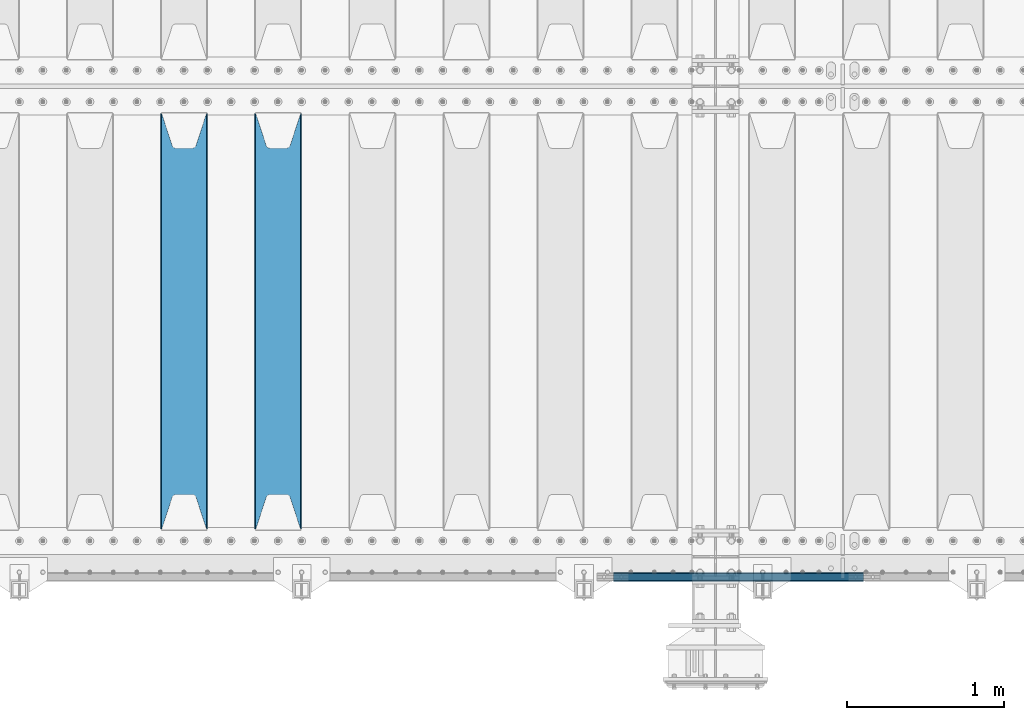
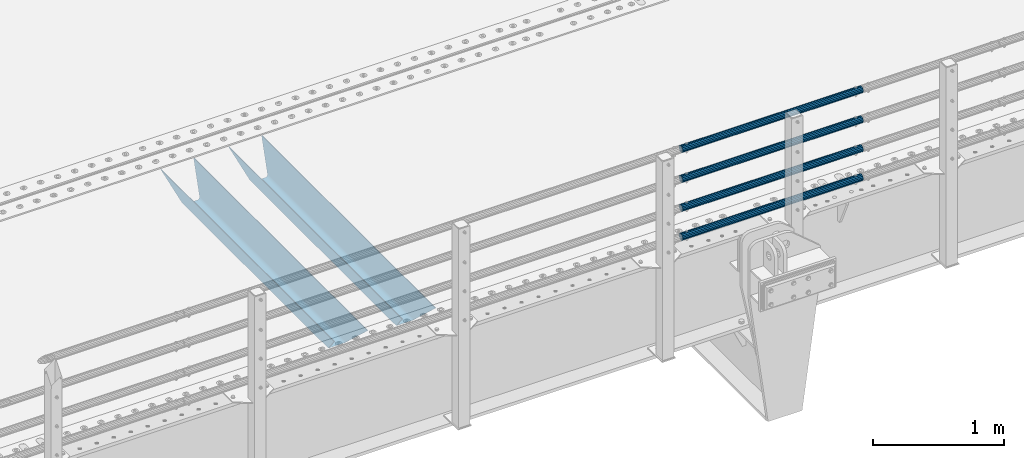
# One storey, part 101 of 219: 6 beams.
"""IFC2X3 building model written with IfcOpenShell, lengths in millimetres."""

import ifcopenshell
import ifcopenshell.guid

model = None  # the IFC model being written
_history = None  # IfcOwnerHistory: only IFC2X3 demands one
_inside = {}  # id of a spatial element -> (the spatial element, [elements in it])
_under = {}  # id of a project, library or spatial element -> (it, [spatial elements below it])
_declared = {}  # id of a project -> (the project, [libraries it declares])
_typed = {}  # id of a type object -> (the type object, [elements of that type])
_made_of = {}  # id of a material, layer set ... -> (it, [elements and type objects made of it])


def new_model(schema):
    """Start an empty IFC model of exactly this schema.

    Asked for "IFC4X3", IfcOpenShell would pick the latest addendum, in which some entities
    have other attributes; the version numbers below select the first issue.
    IFC2X3 requires an IfcOwnerHistory on every rooted entity: one is made here for all.
    """
    global model, _history
    if schema == "IFC4X3":
        model = ifcopenshell.file(schema_version=(4, 3, 0, 0))
    else:
        model = ifcopenshell.file(schema=schema)
    _inside.clear()
    _under.clear()
    _declared.clear()
    _typed.clear()
    _made_of.clear()
    _history = None
    if model.schema == "IFC2X3":
        org = make("IfcOrganization", Name="unknown")
        user = make(
            "IfcPersonAndOrganization",
            ThePerson=make("IfcPerson", FamilyName="unknown"),
            TheOrganization=org,
        )
        app = make(
            "IfcApplication",
            ApplicationDeveloper=org,
            Version="unknown",
            ApplicationFullName="unknown",
            ApplicationIdentifier="unknown",
        )
        _history = make(
            "IfcOwnerHistory",
            OwningUser=user,
            OwningApplication=app,
            ChangeAction="ADDED",
            CreationDate=0,
        )
    return model


def make(cls, **values):
    """One entity of the class cls with the attributes given. An attribute that is None is left unset."""
    return model.create_entity(
        cls, **{name: value for name, value in values.items() if value is not None}
    )


def rooted(cls, **values):
    """An entity with a GlobalId (a new one), such as an element, a storey or a relation."""
    return make(cls, GlobalId=ifcopenshell.guid.new(), OwnerHistory=_history, **values)


def si_unit(unit_type, name, prefix=None):
    """IfcSIUnit, for example si_unit("LENGTHUNIT", "METRE", prefix="MILLI")."""
    return make("IfcSIUnit", UnitType=unit_type, Prefix=prefix, Name=name)


def assignment(units):
    """IfcUnitAssignment: the units of a project."""
    return None if units is None else make("IfcUnitAssignment", Units=units)


def point(xyz):
    """IfcCartesianPoint."""
    return None if xyz is None else make("IfcCartesianPoint", Coordinates=xyz)


def direction(xyz):
    """IfcDirection."""
    return None if xyz is None else make("IfcDirection", DirectionRatios=xyz)


def frame(location, z_axis=None, x_axis=None):
    """IfcAxis2Placement3D, a coordinate frame: its origin and axes. An axis left out is left unset."""
    return make(
        "IfcAxis2Placement3D",
        Location=point(location),
        Axis=direction(z_axis),
        RefDirection=direction(x_axis),
    )


def origin_with_axes():
    """The frame at (0, 0, 0) with the z axis (0, 0, 1) and the x axis (1, 0, 0) written out."""
    return frame((0.0, 0.0, 0.0), z_axis=(0.0, 0.0, 1.0), x_axis=(1.0, 0.0, 0.0))


def place(relative_to, where):
    """IfcLocalPlacement: puts the frame where relative to a parent placement (None: the world)."""
    return make(
        "IfcLocalPlacement", PlacementRelTo=relative_to, RelativePlacement=where
    )


def context(
    kind, dimensions, precision=None, world=None, true_north=None, identifier=None
):
    """IfcGeometricRepresentationContext, for example the 3D "Model" context."""
    return make(
        "IfcGeometricRepresentationContext",
        ContextIdentifier=identifier,
        ContextType=kind,
        CoordinateSpaceDimension=dimensions,
        Precision=precision,
        WorldCoordinateSystem=world,
        TrueNorth=true_north,
    )


def subcontext(parent, identifier, kind, view, scale=None):
    """IfcGeometricRepresentationSubContext, for example "Body" below "Model"."""
    return make(
        "IfcGeometricRepresentationSubContext",
        ContextIdentifier=identifier,
        ContextType=kind,
        ParentContext=parent,
        TargetScale=scale,
        TargetView=view,
    )


def project(units=None, contexts=None):
    """IfcProject with its units and contexts."""
    return rooted(
        "IfcProject",
        Name="project",
        RepresentationContexts=contexts,
        UnitsInContext=assignment(units),
    )


def spatial(cls, under=None, at=None, **own):
    """A site, building, storey or space (cls), placed at a placement, below another one or the project."""
    s = rooted(cls, ObjectPlacement=at, **own)
    if under is not None:
        _under.setdefault(under.id(), (under, []))[1].append(s)
    return s


def faces_of(points, faces, orient=None, outer=None):
    """IfcFace entities. A face is a list of loops; a loop is a list of indices into points, from 0.

    orient and outer hold one flag for each loop. By default every Orientation is true, the
    first loop of a face is its IfcFaceOuterBound and the others are IfcFaceBound.
    """
    made = []
    for i, loops in enumerate(faces):
        bounds = []
        for j, loop in enumerate(loops):
            is_outer = j == 0 if outer is None else outer[i][j]
            bounds.append(
                make(
                    "IfcFaceOuterBound" if is_outer else "IfcFaceBound",
                    Bound=make("IfcPolyLoop", Polygon=[points[k] for k in loop]),
                    Orientation=True if orient is None else orient[i][j],
                )
            )
        made.append(make("IfcFace", Bounds=bounds))
    return made


def faceted_brep(points, faces, orient=None, outer=None, voids=None):
    """IfcFacetedBrep: a solid bounded by flat faces; with voids (closed shells), ...WithVoids."""
    shared = [point(p) for p in points]
    hull = make("IfcClosedShell", CfsFaces=faces_of(shared, faces, orient, outer))
    if voids is None:
        return make("IfcFacetedBrep", Outer=hull)
    return make(
        "IfcFacetedBrepWithVoids",
        Outer=hull,
        Voids=[
            make(cls, CfsFaces=faces_of(shared, fs, o, b)) for cls, fs, o, b in voids
        ],
    )


def shape(context_of_items, identifier, shape_type, items):
    """IfcShapeRepresentation: the items that make up one representation, for example the "Body"."""
    return make(
        "IfcShapeRepresentation",
        ContextOfItems=context_of_items,
        RepresentationIdentifier=identifier,
        RepresentationType=shape_type,
        Items=items,
    )


def material(Name=None, Category=None):
    """IfcMaterial."""
    return make("IfcMaterial", Name=Name, Category=Category)


def made_of(thing, what):
    """Note that an element or type object is made of a material, layer set ...; save() writes the relation."""
    if what is not None:
        _made_of.setdefault(what.id(), (what, []))[1].append(thing)
    return thing


def type_object(cls, material=None, **own):
    """A type object (cls), such as IfcWallType, which elements share."""
    return made_of(rooted(cls, **own), material)


def element(
    cls,
    number,
    at=None,
    inside=None,
    cuts=None,
    type_object=None,
    material=None,
    context=None,
    identifier="Body",
    shape_type=None,
    held_by="IfcProductDefinitionShape",
    body=None,
    shapes=None,
    **own,
):
    """One element of the class cls, such as IfcWall. Its Tag is "e" and its number.

    at: its placement. inside: the storey or other place that contains it. cuts: it is an
    opening in that element (IfcRelVoidsElement). A single representation is given by context,
    identifier, shape_type and body (its items); several are given by shapes. held_by: the class
    of the entity that holds the representations. save() writes the other relations.
    """
    e = rooted(cls, Tag="e%d" % number, ObjectPlacement=at, **own)
    if body is not None:
        shapes = [shape(context, identifier, shape_type, body)]
    if shapes is not None:
        e.Representation = make(held_by, Representations=shapes)
    if inside is not None:
        _inside.setdefault(inside.id(), (inside, []))[1].append(e)
    if cuts is not None:
        rooted(
            "IfcRelVoidsElement", RelatingBuildingElement=cuts, RelatedOpeningElement=e
        )
    if type_object is not None:
        _typed.setdefault(type_object.id(), (type_object, []))[1].append(e)
    return made_of(e, material)


def aggregate(whole, parts):
    """IfcRelAggregates: a whole, such as a stair, and the parts it consists of."""
    return rooted("IfcRelAggregates", RelatingObject=whole, RelatedObjects=parts)


def save(model, path):
    """Write the relations noted so far, then the file.

    IfcRelAggregates (storeys below a building ...), IfcRelContainedInSpatialStructure (elements
    in a storey), IfcRelDefinesByType, IfcRelAssociatesMaterial and IfcRelDeclares: one each for
    every whole, place, type object, material and project.
    """
    for whole, parts in _under.values():
        aggregate(whole, parts)
    for where, things in _inside.values():
        rooted(
            "IfcRelContainedInSpatialStructure",
            RelatedElements=things,
            RelatingStructure=where,
        )
    for kind, things in _typed.values():
        rooted("IfcRelDefinesByType", RelatedObjects=things, RelatingType=kind)
    for what, things in _made_of.values():
        rooted("IfcRelAssociatesMaterial", RelatedObjects=things, RelatingMaterial=what)
    for by, libraries in _declared.values():
        rooted("IfcRelDeclares", RelatingContext=by, RelatedDefinitions=libraries)
    model.write(path)


model = new_model("IFC2X3")

# Units and contexts
model_context = context("Model", 3, precision=1e-05, world=origin_with_axes())
body_context = subcontext(model_context, "Body", "Model", "MODEL_VIEW")
ifc_project = project(units=[si_unit("LENGTHUNIT", "METRE", prefix="MILLI"), si_unit("AREAUNIT", "SQUARE_METRE"), si_unit("VOLUMEUNIT", "CUBIC_METRE"), si_unit("MASSUNIT", "GRAM", prefix="KILO"), si_unit("TIMEUNIT", "SECOND"), si_unit("PLANEANGLEUNIT", "RADIAN"), si_unit("SOLIDANGLEUNIT", "STERADIAN"), si_unit("THERMODYNAMICTEMPERATUREUNIT", "DEGREE_CELSIUS"), si_unit("LUMINOUSINTENSITYUNIT", "LUMEN")], contexts=[model_context])

# Site, building, storey
site_placement = place(None, origin_with_axes())
site = spatial("IfcSite", under=ifc_project, at=site_placement, CompositionType="ELEMENT")
building_placement = place(site_placement, origin_with_axes())
building = spatial("IfcBuilding", under=site, at=building_placement, Name="Standard", CompositionType="ELEMENT")
storey_placement = place(building_placement, origin_with_axes())
storey = spatial("IfcBuildingStorey", under=building, at=storey_placement, Name="Undefined", CompositionType="ELEMENT", Elevation=0.0)

# Beams
ifc_material_1 = material(Name="STEEL/S355N")
beam_type_1 = type_object("IfcBeamType", PredefinedType="NOTDEFINED")
beam_1_placement = place(storey_placement, frame((7600.0, 24175.0, -115.0), z_axis=(0.0, 0.0, 1.0), x_axis=(0.0, 1.0, 0.0)))
element("IfcBeam", 1, at=beam_1_placement, inside=storey, type_object=beam_type_1, material=ifc_material_1, context=body_context, shape_type="Brep", body=[
    faceted_brep([(0.0, 150.0, 115.0), (0.0, 143.690000000001, 115.0), (2650.00000000297, 143.690000000001, 115.0), (2650.00000000297, 150.0, 115.0), (2650.00000000297, 142.0595652184, 110.000000003094), (2650.00000000297, 148.3695652184, 110.000000003094), (2441.90079219209, -80.110360073113, -98.0992078077845), (2437.7588105432, -77.5672621345566, -102.241189456673), (2434.06523489747, -74.4080125315541, -105.934765102404), (2430.9108609509, -70.7102721255742, -109.089139048974), (2428.37322971128, -66.5649389910068, -111.626770288588), (2426.51472138055, -62.0739139532889, -113.485278619323), (2425.38102192092, -57.3475956567672, -114.618978078955), (2424.99999999988, -52.5021667386536, -115.0), (2424.99999999988, 52.5021667386536, -115.0), (2425.38102192092, 57.3475956567672, -114.618978078955), (2426.51472138055, 62.0739139532889, -113.485278619323), (2428.37322971128, 66.5649389910068, -111.626770288588), (2430.9108609509, 70.7102721255742, -109.089139048974), (2434.06523489747, 74.4080125315541, -105.934765102404), (2437.7588105432, 77.5672621345566, -102.241189456673), (2441.90079219209, 80.110360073113, -98.0992078077846), (2446.38936140512, 81.9747917625791, -93.6106385947584), (2448.2494850041, 76.2713538057269, -91.7505149957729), (2444.62967112263, 74.7677798626082, -95.3703288772456), (2441.28936334127, 72.7168944282894, -98.710636658607), (2438.31067330439, 70.1691124903828, -101.689326695487), (2435.76682334748, 67.1870637758839, -104.233176652398), (2433.72034654134, 63.8440531834913, -106.279653458539), (2432.22154950042, 60.2222587982342, -107.778450499454), (2431.30727574265, 56.4107117849107, -108.692724257221), (2430.99999999987, 52.5031078186894, -109.0), (2430.99999999987, -52.5031078186894, -109.0), (2431.30727574265, -56.4107117849107, -108.692724257221), (2432.22154950042, -60.2222587982342, -107.778450499454), (2433.72034654134, -63.8440531834913, -106.279653458539), (2435.76682334748, -67.1870637758839, -104.233176652398), (2438.31067330439, -70.1691124903828, -101.689326695487), (2441.28936334127, -72.7168944282894, -98.7106366586071), (2444.62967112263, -74.7677798626082, -95.3703288772457), (2448.2494850041, -76.2713538057269, -91.7505149957729), (2650.00000000297, -142.0595652184, 110.000000003094), (2650.00000000297, -148.3695652184, 110.000000003094), (2446.38936140512, -81.9747917625791, -93.6106385947584), (2650.00000000297, -143.690000000001, 115.0), (2650.00000000297, -150.0, 115.0), (0.0, -143.690000000001, 115.0), (0.0, -150.0, 115.0), (0.0, -148.369565218261, 110.000000002667), (203.610638597427, -81.9747917625791, -93.6106385947584), (208.09920781045, -80.110360073113, -98.0992078077845), (212.241189459342, -77.5672621345566, -102.241189456673), (215.93476510507, -74.4080125315541, -105.934765102404), (219.089139051641, -70.7102721255742, -109.089139048974), (221.626770291256, -66.5649389910068, -111.626770288588), (223.485278621989, -62.0739139532889, -113.485278619323), (224.618978081624, -57.3475956567672, -114.618978078955), (225.000000002663, -52.5021667386536, -115.0), (225.000000002663, 52.5021667386536, -115.0), (224.618978081624, 57.3475956567672, -114.618978078955), (223.485278621989, 62.0739139532889, -113.485278619323), (221.626770291256, 66.5649389910068, -111.626770288588), (219.089139051641, 70.7102721255742, -109.089139048974), (215.93476510507, 74.4080125315541, -105.934765102404), (212.241189459342, 77.5672621345566, -102.241189456673), (208.09920781045, 80.110360073113, -98.0992078077846), (203.610638597427, 81.9747917625791, -93.6106385947584), (0.0, 148.369565218261, 110.000000002667), (0.0, 142.059565218262, 110.000000002667), (201.750514998439, 76.2713538057269, -91.7505149957729), (205.370328879915, 74.7677798626082, -95.3703288772456), (208.710636661275, 72.7168944282894, -98.710636658607), (211.689326698157, 70.1691124903828, -101.689326695487), (214.233176655063, 67.1870637758839, -104.233176652398), (216.279653461206, 63.8440531834913, -106.279653458539), (217.778450502123, 60.2222587982342, -107.778450499454), (218.69272425989, 56.4107117849107, -108.692724257221), (219.00000000267, 52.5031078186894, -109.0), (219.00000000267, -52.5031078186894, -109.0), (218.69272425989, -56.4107117849107, -108.692724257221), (217.778450502123, -60.2222587982342, -107.778450499454), (216.279653461206, -63.8440531834913, -106.279653458539), (214.233176655063, -67.1870637758839, -104.233176652398), (211.689326698157, -70.1691124903828, -101.689326695487), (208.710636661275, -72.7168944282894, -98.7106366586071), (205.370328879915, -74.7677798626082, -95.3703288772457), (201.750514998439, -76.2713538057269, -91.7505149957729), (0.0, -142.059565218262, 110.000000002667)], [[[0, 1, 2, 3]], [[3, 2, 4, 5]], [[6, 7, 8, 9, 10, 11, 12, 13, 14, 15, 16, 17, 18, 19, 20, 21, 22, 5, 4, 23, 24, 25, 26, 27, 28, 29, 30, 31, 32, 33, 34, 35, 36, 37, 38, 39, 40, 41, 42, 43]], [[44, 45, 42, 41]], [[46, 47, 45, 44]], [[43, 42, 45, 47, 48, 49]], [[6, 43, 49, 50]], [[7, 6, 50, 51]], [[8, 7, 51, 52]], [[9, 8, 52, 53]], [[10, 9, 53, 54]], [[11, 10, 54, 55]], [[12, 11, 55, 56]], [[13, 12, 56, 57]], [[14, 13, 57, 58]], [[15, 14, 58, 59]], [[16, 15, 59, 60]], [[17, 16, 60, 61]], [[18, 17, 61, 62]], [[19, 18, 62, 63]], [[20, 19, 63, 64]], [[21, 20, 64, 65]], [[22, 21, 65, 66]], [[0, 3, 5, 22, 66, 67]], [[1, 0, 67, 68]], [[23, 4, 2, 1, 68, 69]], [[24, 23, 69, 70]], [[25, 24, 70, 71]], [[26, 25, 71, 72]], [[27, 26, 72, 73]], [[28, 27, 73, 74]], [[29, 28, 74, 75]], [[30, 29, 75, 76]], [[31, 30, 76, 77]], [[32, 31, 77, 78]], [[33, 32, 78, 79]], [[34, 33, 79, 80]], [[35, 34, 80, 81]], [[36, 35, 81, 82]], [[37, 36, 82, 83]], [[38, 37, 83, 84]], [[39, 38, 84, 85]], [[40, 39, 85, 86]], [[46, 44, 41, 40, 86, 87]], [[47, 46, 87, 48]], [[86, 85, 84, 83, 82, 81, 80, 79, 78, 77, 76, 75, 74, 73, 72, 71, 70, 69, 68, 67, 66, 65, 64, 63, 62, 61, 60, 59, 58, 57, 56, 55, 54, 53, 52, 51, 50, 49, 48, 87]]]),
])
beam_2_placement = place(storey_placement, frame((7000.0, 24175.0, -115.0), z_axis=(0.0, 0.0, 1.0), x_axis=(0.0, 1.0, 0.0)))
element("IfcBeam", 2, at=beam_2_placement, inside=storey, type_object=beam_type_1, material=ifc_material_1, context=body_context, shape_type="Brep", body=[
    faceted_brep([(0.0, 150.0, 115.0), (0.0, 143.690000000001, 115.0), (2650.00000000297, 143.690000000001, 115.0), (2650.00000000297, 150.0, 115.0), (2650.00000000297, 142.0595652184, 110.000000003094), (2650.00000000297, 148.3695652184, 110.000000003094), (2441.90079219209, -80.110360073113, -98.0992078077845), (2437.7588105432, -77.5672621345566, -102.241189456673), (2434.06523489747, -74.4080125315541, -105.934765102404), (2430.9108609509, -70.7102721255742, -109.089139048974), (2428.37322971128, -66.5649389910068, -111.626770288588), (2426.51472138055, -62.0739139532889, -113.485278619323), (2425.38102192092, -57.3475956567672, -114.618978078955), (2424.99999999988, -52.5021667386536, -115.0), (2424.99999999988, 52.5021667386536, -115.0), (2425.38102192092, 57.3475956567672, -114.618978078955), (2426.51472138055, 62.0739139532889, -113.485278619323), (2428.37322971128, 66.5649389910068, -111.626770288588), (2430.9108609509, 70.7102721255742, -109.089139048974), (2434.06523489747, 74.4080125315541, -105.934765102404), (2437.7588105432, 77.5672621345566, -102.241189456673), (2441.90079219209, 80.110360073113, -98.0992078077846), (2446.38936140512, 81.9747917625791, -93.6106385947584), (2448.2494850041, 76.2713538057269, -91.7505149957729), (2444.62967112263, 74.7677798626082, -95.3703288772456), (2441.28936334127, 72.7168944282894, -98.710636658607), (2438.31067330439, 70.1691124903828, -101.689326695487), (2435.76682334748, 67.1870637758839, -104.233176652398), (2433.72034654134, 63.8440531834913, -106.279653458539), (2432.22154950042, 60.2222587982342, -107.778450499454), (2431.30727574265, 56.4107117849107, -108.692724257221), (2430.99999999987, 52.5031078186894, -109.0), (2430.99999999987, -52.5031078186894, -109.0), (2431.30727574265, -56.4107117849107, -108.692724257221), (2432.22154950042, -60.2222587982342, -107.778450499454), (2433.72034654134, -63.8440531834913, -106.279653458539), (2435.76682334748, -67.1870637758839, -104.233176652398), (2438.31067330439, -70.1691124903828, -101.689326695487), (2441.28936334127, -72.7168944282894, -98.7106366586071), (2444.62967112263, -74.7677798626082, -95.3703288772457), (2448.2494850041, -76.2713538057269, -91.7505149957729), (2650.00000000297, -142.0595652184, 110.000000003094), (2650.00000000297, -148.3695652184, 110.000000003094), (2446.38936140512, -81.9747917625791, -93.6106385947584), (2650.00000000297, -143.690000000001, 115.0), (2650.00000000297, -150.0, 115.0), (0.0, -143.690000000001, 115.0), (0.0, -150.0, 115.0), (0.0, -148.369565218261, 110.000000002667), (203.610638597427, -81.9747917625791, -93.6106385947584), (208.09920781045, -80.110360073113, -98.0992078077845), (212.241189459342, -77.5672621345566, -102.241189456673), (215.93476510507, -74.4080125315541, -105.934765102404), (219.089139051641, -70.7102721255742, -109.089139048974), (221.626770291256, -66.5649389910068, -111.626770288588), (223.485278621989, -62.0739139532889, -113.485278619323), (224.618978081624, -57.3475956567672, -114.618978078955), (225.000000002663, -52.5021667386536, -115.0), (225.000000002663, 52.5021667386536, -115.0), (224.618978081624, 57.3475956567672, -114.618978078955), (223.485278621989, 62.0739139532889, -113.485278619323), (221.626770291256, 66.5649389910068, -111.626770288588), (219.089139051641, 70.7102721255742, -109.089139048974), (215.93476510507, 74.4080125315541, -105.934765102404), (212.241189459342, 77.5672621345566, -102.241189456673), (208.09920781045, 80.110360073113, -98.0992078077846), (203.610638597427, 81.9747917625791, -93.6106385947584), (0.0, 148.369565218261, 110.000000002667), (0.0, 142.059565218262, 110.000000002667), (201.750514998439, 76.2713538057269, -91.7505149957729), (205.370328879915, 74.7677798626082, -95.3703288772456), (208.710636661275, 72.7168944282894, -98.710636658607), (211.689326698157, 70.1691124903828, -101.689326695487), (214.233176655063, 67.1870637758839, -104.233176652398), (216.279653461206, 63.8440531834913, -106.279653458539), (217.778450502123, 60.2222587982342, -107.778450499454), (218.69272425989, 56.4107117849107, -108.692724257221), (219.00000000267, 52.5031078186894, -109.0), (219.00000000267, -52.5031078186894, -109.0), (218.69272425989, -56.4107117849107, -108.692724257221), (217.778450502123, -60.2222587982342, -107.778450499454), (216.279653461206, -63.8440531834913, -106.279653458539), (214.233176655063, -67.1870637758839, -104.233176652398), (211.689326698157, -70.1691124903828, -101.689326695487), (208.710636661275, -72.7168944282894, -98.7106366586071), (205.370328879915, -74.7677798626082, -95.3703288772457), (201.750514998439, -76.2713538057269, -91.7505149957729), (0.0, -142.059565218262, 110.000000002667)], [[[0, 1, 2, 3]], [[3, 2, 4, 5]], [[6, 7, 8, 9, 10, 11, 12, 13, 14, 15, 16, 17, 18, 19, 20, 21, 22, 5, 4, 23, 24, 25, 26, 27, 28, 29, 30, 31, 32, 33, 34, 35, 36, 37, 38, 39, 40, 41, 42, 43]], [[44, 45, 42, 41]], [[46, 47, 45, 44]], [[43, 42, 45, 47, 48, 49]], [[6, 43, 49, 50]], [[7, 6, 50, 51]], [[8, 7, 51, 52]], [[9, 8, 52, 53]], [[10, 9, 53, 54]], [[11, 10, 54, 55]], [[12, 11, 55, 56]], [[13, 12, 56, 57]], [[14, 13, 57, 58]], [[15, 14, 58, 59]], [[16, 15, 59, 60]], [[17, 16, 60, 61]], [[18, 17, 61, 62]], [[19, 18, 62, 63]], [[20, 19, 63, 64]], [[21, 20, 64, 65]], [[22, 21, 65, 66]], [[0, 3, 5, 22, 66, 67]], [[1, 0, 67, 68]], [[23, 4, 2, 1, 68, 69]], [[24, 23, 69, 70]], [[25, 24, 70, 71]], [[26, 25, 71, 72]], [[27, 26, 72, 73]], [[28, 27, 73, 74]], [[29, 28, 74, 75]], [[30, 29, 75, 76]], [[31, 30, 76, 77]], [[32, 31, 77, 78]], [[33, 32, 78, 79]], [[34, 33, 79, 80]], [[35, 34, 80, 81]], [[36, 35, 81, 82]], [[37, 36, 82, 83]], [[38, 37, 83, 84]], [[39, 38, 84, 85]], [[40, 39, 85, 86]], [[46, 44, 41, 40, 86, 87]], [[47, 46, 87, 48]], [[86, 85, 84, 83, 82, 81, 80, 79, 78, 77, 76, 75, 74, 73, 72, 71, 70, 69, 68, 67, 66, 65, 64, 63, 62, 61, 60, 59, 58, 57, 56, 55, 54, 53, 52, 51, 50, 49, 48, 87]]]),
])
ifc_material_2 = material()
beam_type_2 = type_object("IfcBeamType", PredefinedType="NOTDEFINED")
beam_3_placement = place(storey_placement, frame((11331.9999999999, 23870.1500000002, 149.849999999748), z_axis=(0.0, 0.0, -1.0), x_axis=(-1.0, 0.0, 0.0)))
element("IfcBeam", 3, at=beam_3_placement, inside=storey, type_object=beam_type_2, material=ifc_material_2, context=body_context, shape_type="Brep", body=[
    faceted_brep([(0.0, -26.5500000000029, 0.0), (0.0, -24.5290015881765, 10.1602451292931), (1594.0, -24.5290015881765, 10.1602451292931), (1594.0, -26.5500000000029, 0.0), (0.0, -18.7736850405054, 18.7736850405028), (1594.0, -18.7736850405054, 18.7736850405028), (0.0, -10.1602451292929, 24.5290015881747), (1594.0, -10.1602451292929, 24.5290015881747), (0.0, 0.0, 26.55), (1594.0, 0.0, 26.55), (0.0, 10.1602451292929, 24.5290015881747), (1594.0, 10.1602451292929, 24.5290015881747), (0.0, 18.7736850405054, 18.7736850405028), (1594.0, 18.7736850405054, 18.7736850405028), (0.0, 24.5290015881765, 10.1602451292931), (1594.0, 24.5290015881765, 10.1602451292931), (0.0, 26.5500000000029, 0.0), (1594.0, 26.5500000000029, 0.0), (0.0, 24.5290015881765, -10.1602451292931), (1594.0, 24.5290015881765, -10.1602451292931), (0.0, 18.7736850405054, -18.7736850405028), (1594.0, 18.7736850405054, -18.7736850405028), (0.0, 10.1602451292929, -24.5290015881747), (1594.0, 10.1602451292929, -24.5290015881747), (0.0, 0.0, -26.55), (1594.0, 0.0, -26.55), (0.0, -10.1602451292929, -24.5290015881747), (1594.0, -10.1602451292929, -24.5290015881747), (0.0, -18.7736850405054, -18.7736850405028), (1594.0, -18.7736850405054, -18.7736850405028), (0.0, -24.5290015881765, -10.1602451292931), (1594.0, -24.5290015881765, -10.1602451292931), (0.0, -30.1500000000015, 0.0), (0.0, -27.8549679052157, -11.5379054858076), (1594.0, -27.8549679052157, -11.5379054858075), (1594.0, -30.1500000000015, 0.0), (0.0, -21.3192694527752, -21.3192694527752), (1594.0, -21.3192694527752, -21.3192694527744), (0.0, -11.5379054858058, -27.8549679052157), (1594.0, -11.5379054858058, -27.8549679052153), (0.0, 0.0, -30.1499999999996), (1594.0, 0.0, -30.15), (0.0, 11.5379054858058, -27.8549679052157), (1594.0, 11.5379054858058, -27.8549679052153), (0.0, 21.3192694527752, -21.3192694527752), (1594.0, 21.3192694527752, -21.3192694527744), (0.0, 27.8549679052157, -11.5379054858076), (1594.0, 27.8549679052157, -11.5379054858074), (0.0, 30.1500000000015, 0.0), (1594.0, 30.1500000000015, 0.0), (0.0, 27.8549679052157, 11.5379054858076), (1594.0, 27.8549679052157, 11.5379054858075), (0.0, 21.3192694527752, 21.3192694527752), (1594.0, 21.3192694527752, 21.3192694527744), (0.0, 11.5379054858058, 27.8549679052157), (1594.0, 11.5379054858058, 27.8549679052153), (0.0, 0.0, 30.1499999999996), (1594.0, 0.0, 30.15), (0.0, -11.5379054858058, 27.8549679052157), (1594.0, -11.5379054858058, 27.8549679052153), (0.0, -21.3192694527752, 21.3192694527752), (1594.0, -21.3192694527752, 21.3192694527744), (0.0, -27.8549679052157, 11.5379054858076), (1594.0, -27.8549679052157, 11.5379054858075)], [[[0, 1, 2, 3]], [[1, 4, 5, 2]], [[4, 6, 7, 5]], [[6, 8, 9, 7]], [[8, 10, 11, 9]], [[10, 12, 13, 11]], [[12, 14, 15, 13]], [[14, 16, 17, 15]], [[16, 18, 19, 17]], [[18, 20, 21, 19]], [[20, 22, 23, 21]], [[22, 24, 25, 23]], [[24, 26, 27, 25]], [[26, 28, 29, 27]], [[28, 30, 31, 29]], [[30, 0, 3, 31]], [[32, 33, 34, 35]], [[33, 36, 37, 34]], [[36, 38, 39, 37]], [[38, 40, 41, 39]], [[40, 42, 43, 41]], [[42, 44, 45, 43]], [[44, 46, 47, 45]], [[46, 48, 49, 47]], [[48, 50, 51, 49]], [[50, 52, 53, 51]], [[52, 54, 55, 53]], [[54, 56, 57, 55]], [[56, 58, 59, 57]], [[58, 60, 61, 59]], [[60, 62, 63, 61]], [[62, 32, 35, 63]], [[37, 39, 41, 43, 45, 47, 49, 51, 53, 55, 57, 59, 61, 63, 35, 34], [5, 7, 9, 11, 13, 15, 17, 19, 21, 23, 25, 27, 29, 31, 3, 2]], [[62, 60, 58, 56, 54, 52, 50, 48, 46, 44, 42, 40, 38, 36, 33, 32], [30, 28, 26, 24, 22, 20, 18, 16, 14, 12, 10, 8, 6, 4, 1, 0]]]),
])
beam_4_placement = place(storey_placement, frame((11331.9999999999, 23870.1500000002, 420.149999999748), z_axis=(0.0, 0.0, -1.0), x_axis=(-1.0, 0.0, 0.0)))
element("IfcBeam", 4, at=beam_4_placement, inside=storey, type_object=beam_type_2, material=ifc_material_2, context=body_context, shape_type="Brep", body=[
    faceted_brep([(0.0, -26.5500000000029, 0.0), (0.0, -24.5290015881765, 10.1602451292931), (1594.0, -24.5290015881765, 10.1602451292931), (1594.0, -26.5500000000029, 0.0), (0.0, -18.7736850405054, 18.7736850405028), (1594.0, -18.7736850405054, 18.7736850405028), (0.0, -10.1602451292929, 24.5290015881747), (1594.0, -10.1602451292929, 24.5290015881747), (0.0, 0.0, 26.55), (1594.0, 0.0, 26.55), (0.0, 10.1602451292929, 24.5290015881747), (1594.0, 10.1602451292929, 24.5290015881747), (0.0, 18.7736850405054, 18.7736850405028), (1594.0, 18.7736850405054, 18.7736850405028), (0.0, 24.5290015881765, 10.1602451292931), (1594.0, 24.5290015881765, 10.1602451292931), (0.0, 26.5500000000029, 0.0), (1594.0, 26.5500000000029, 0.0), (0.0, 24.5290015881765, -10.1602451292931), (1594.0, 24.5290015881765, -10.1602451292931), (0.0, 18.7736850405054, -18.7736850405028), (1594.0, 18.7736850405054, -18.7736850405028), (0.0, 10.1602451292929, -24.5290015881747), (1594.0, 10.1602451292929, -24.5290015881747), (0.0, 0.0, -26.55), (1594.0, 0.0, -26.55), (0.0, -10.1602451292929, -24.5290015881747), (1594.0, -10.1602451292929, -24.5290015881747), (0.0, -18.7736850405054, -18.7736850405028), (1594.0, -18.7736850405054, -18.7736850405028), (0.0, -24.5290015881765, -10.1602451292931), (1594.0, -24.5290015881765, -10.1602451292931), (0.0, -30.1500000000015, 0.0), (0.0, -27.8549679052157, -11.5379054858076), (1594.0, -27.8549679052157, -11.5379054858075), (1594.0, -30.1500000000015, 0.0), (0.0, -21.3192694527752, -21.3192694527752), (1594.0, -21.3192694527752, -21.3192694527744), (0.0, -11.5379054858058, -27.8549679052157), (1594.0, -11.5379054858058, -27.8549679052153), (0.0, 0.0, -30.1499999999996), (1594.0, 0.0, -30.15), (0.0, 11.5379054858058, -27.8549679052157), (1594.0, 11.5379054858058, -27.8549679052153), (0.0, 21.3192694527752, -21.3192694527752), (1594.0, 21.3192694527752, -21.3192694527744), (0.0, 27.8549679052157, -11.5379054858076), (1594.0, 27.8549679052157, -11.5379054858074), (0.0, 30.1500000000015, 0.0), (1594.0, 30.1500000000015, 0.0), (0.0, 27.8549679052157, 11.5379054858076), (1594.0, 27.8549679052157, 11.5379054858075), (0.0, 21.3192694527752, 21.3192694527752), (1594.0, 21.3192694527752, 21.3192694527744), (0.0, 11.5379054858058, 27.8549679052157), (1594.0, 11.5379054858058, 27.8549679052153), (0.0, 0.0, 30.1499999999996), (1594.0, 0.0, 30.15), (0.0, -11.5379054858058, 27.8549679052157), (1594.0, -11.5379054858058, 27.8549679052153), (0.0, -21.3192694527752, 21.3192694527752), (1594.0, -21.3192694527752, 21.3192694527744), (0.0, -27.8549679052157, 11.5379054858076), (1594.0, -27.8549679052157, 11.5379054858075)], [[[0, 1, 2, 3]], [[1, 4, 5, 2]], [[4, 6, 7, 5]], [[6, 8, 9, 7]], [[8, 10, 11, 9]], [[10, 12, 13, 11]], [[12, 14, 15, 13]], [[14, 16, 17, 15]], [[16, 18, 19, 17]], [[18, 20, 21, 19]], [[20, 22, 23, 21]], [[22, 24, 25, 23]], [[24, 26, 27, 25]], [[26, 28, 29, 27]], [[28, 30, 31, 29]], [[30, 0, 3, 31]], [[32, 33, 34, 35]], [[33, 36, 37, 34]], [[36, 38, 39, 37]], [[38, 40, 41, 39]], [[40, 42, 43, 41]], [[42, 44, 45, 43]], [[44, 46, 47, 45]], [[46, 48, 49, 47]], [[48, 50, 51, 49]], [[50, 52, 53, 51]], [[52, 54, 55, 53]], [[54, 56, 57, 55]], [[56, 58, 59, 57]], [[58, 60, 61, 59]], [[60, 62, 63, 61]], [[62, 32, 35, 63]], [[37, 39, 41, 43, 45, 47, 49, 51, 53, 55, 57, 59, 61, 63, 35, 34], [5, 7, 9, 11, 13, 15, 17, 19, 21, 23, 25, 27, 29, 31, 3, 2]], [[62, 60, 58, 56, 54, 52, 50, 48, 46, 44, 42, 40, 38, 36, 33, 32], [30, 28, 26, 24, 22, 20, 18, 16, 14, 12, 10, 8, 6, 4, 1, 0]]]),
])
beam_5_placement = place(storey_placement, frame((11331.9999999999, 23870.1500000002, 969.849999999748), z_axis=(0.0, 0.0, -1.0), x_axis=(-1.0, 0.0, 0.0)))
element("IfcBeam", 5, at=beam_5_placement, inside=storey, type_object=beam_type_2, material=ifc_material_2, context=body_context, shape_type="Brep", body=[
    faceted_brep([(0.0, -26.5500000000029, 0.0), (0.0, -24.5290015881765, 10.1602451292931), (1594.0, -24.5290015881765, 10.1602451292931), (1594.0, -26.5500000000029, 0.0), (0.0, -18.7736850405054, 18.7736850405028), (1594.0, -18.7736850405054, 18.7736850405028), (0.0, -10.1602451292929, 24.5290015881747), (1594.0, -10.1602451292929, 24.5290015881747), (0.0, 0.0, 26.55), (1594.0, 0.0, 26.55), (0.0, 10.1602451292929, 24.5290015881747), (1594.0, 10.1602451292929, 24.5290015881747), (0.0, 18.7736850405054, 18.7736850405028), (1594.0, 18.7736850405054, 18.7736850405028), (0.0, 24.5290015881765, 10.1602451292931), (1594.0, 24.5290015881765, 10.1602451292931), (0.0, 26.5500000000029, 0.0), (1594.0, 26.5500000000029, 0.0), (0.0, 24.5290015881765, -10.1602451292931), (1594.0, 24.5290015881765, -10.1602451292931), (0.0, 18.7736850405054, -18.7736850405028), (1594.0, 18.7736850405054, -18.7736850405028), (0.0, 10.1602451292929, -24.5290015881747), (1594.0, 10.1602451292929, -24.5290015881747), (0.0, 0.0, -26.55), (1594.0, 0.0, -26.55), (0.0, -10.1602451292929, -24.5290015881747), (1594.0, -10.1602451292929, -24.5290015881747), (0.0, -18.7736850405054, -18.7736850405028), (1594.0, -18.7736850405054, -18.7736850405028), (0.0, -24.5290015881765, -10.1602451292931), (1594.0, -24.5290015881765, -10.1602451292931), (0.0, -30.1500000000015, 0.0), (0.0, -27.8549679052157, -11.5379054858076), (1594.0, -27.8549679052157, -11.5379054858075), (1594.0, -30.1500000000015, 0.0), (0.0, -21.3192694527752, -21.3192694527752), (1594.0, -21.3192694527752, -21.3192694527744), (0.0, -11.5379054858058, -27.8549679052157), (1594.0, -11.5379054858058, -27.8549679052153), (0.0, 0.0, -30.1499999999996), (1594.0, 0.0, -30.15), (0.0, 11.5379054858058, -27.8549679052157), (1594.0, 11.5379054858058, -27.8549679052153), (0.0, 21.3192694527752, -21.3192694527752), (1594.0, 21.3192694527752, -21.3192694527744), (0.0, 27.8549679052157, -11.5379054858076), (1594.0, 27.8549679052157, -11.5379054858074), (0.0, 30.1500000000015, 0.0), (1594.0, 30.1500000000015, 0.0), (0.0, 27.8549679052157, 11.5379054858076), (1594.0, 27.8549679052157, 11.5379054858075), (0.0, 21.3192694527752, 21.3192694527752), (1594.0, 21.3192694527752, 21.3192694527744), (0.0, 11.5379054858058, 27.8549679052157), (1594.0, 11.5379054858058, 27.8549679052153), (0.0, 0.0, 30.1499999999996), (1594.0, 0.0, 30.15), (0.0, -11.5379054858058, 27.8549679052157), (1594.0, -11.5379054858058, 27.8549679052153), (0.0, -21.3192694527752, 21.3192694527752), (1594.0, -21.3192694527752, 21.3192694527744), (0.0, -27.8549679052157, 11.5379054858076), (1594.0, -27.8549679052157, 11.5379054858075)], [[[0, 1, 2, 3]], [[1, 4, 5, 2]], [[4, 6, 7, 5]], [[6, 8, 9, 7]], [[8, 10, 11, 9]], [[10, 12, 13, 11]], [[12, 14, 15, 13]], [[14, 16, 17, 15]], [[16, 18, 19, 17]], [[18, 20, 21, 19]], [[20, 22, 23, 21]], [[22, 24, 25, 23]], [[24, 26, 27, 25]], [[26, 28, 29, 27]], [[28, 30, 31, 29]], [[30, 0, 3, 31]], [[32, 33, 34, 35]], [[33, 36, 37, 34]], [[36, 38, 39, 37]], [[38, 40, 41, 39]], [[40, 42, 43, 41]], [[42, 44, 45, 43]], [[44, 46, 47, 45]], [[46, 48, 49, 47]], [[48, 50, 51, 49]], [[50, 52, 53, 51]], [[52, 54, 55, 53]], [[54, 56, 57, 55]], [[56, 58, 59, 57]], [[58, 60, 61, 59]], [[60, 62, 63, 61]], [[62, 32, 35, 63]], [[37, 39, 41, 43, 45, 47, 49, 51, 53, 55, 57, 59, 61, 63, 35, 34], [5, 7, 9, 11, 13, 15, 17, 19, 21, 23, 25, 27, 29, 31, 3, 2]], [[62, 60, 58, 56, 54, 52, 50, 48, 46, 44, 42, 40, 38, 36, 33, 32], [30, 28, 26, 24, 22, 20, 18, 16, 14, 12, 10, 8, 6, 4, 1, 0]]]),
])
beam_6_placement = place(storey_placement, frame((11331.9999999999, 23870.1500000002, 689.849999999748), z_axis=(0.0, 0.0, -1.0), x_axis=(-1.0, 0.0, 0.0)))
element("IfcBeam", 6, at=beam_6_placement, inside=storey, type_object=beam_type_2, material=ifc_material_2, context=body_context, shape_type="Brep", body=[
    faceted_brep([(0.0, -26.5500000000029, 0.0), (0.0, -24.5290015881765, 10.1602451292931), (1594.0, -24.5290015881765, 10.1602451292931), (1594.0, -26.5500000000029, 0.0), (0.0, -18.7736850405054, 18.7736850405028), (1594.0, -18.7736850405054, 18.7736850405028), (0.0, -10.1602451292929, 24.5290015881747), (1594.0, -10.1602451292929, 24.5290015881747), (0.0, 0.0, 26.55), (1594.0, 0.0, 26.55), (0.0, 10.1602451292929, 24.5290015881747), (1594.0, 10.1602451292929, 24.5290015881747), (0.0, 18.7736850405054, 18.7736850405028), (1594.0, 18.7736850405054, 18.7736850405028), (0.0, 24.5290015881765, 10.1602451292931), (1594.0, 24.5290015881765, 10.1602451292931), (0.0, 26.5500000000029, 0.0), (1594.0, 26.5500000000029, 0.0), (0.0, 24.5290015881765, -10.1602451292931), (1594.0, 24.5290015881765, -10.1602451292931), (0.0, 18.7736850405054, -18.7736850405028), (1594.0, 18.7736850405054, -18.7736850405028), (0.0, 10.1602451292929, -24.5290015881747), (1594.0, 10.1602451292929, -24.5290015881747), (0.0, 0.0, -26.55), (1594.0, 0.0, -26.55), (0.0, -10.1602451292929, -24.5290015881747), (1594.0, -10.1602451292929, -24.5290015881747), (0.0, -18.7736850405054, -18.7736850405028), (1594.0, -18.7736850405054, -18.7736850405028), (0.0, -24.5290015881765, -10.1602451292931), (1594.0, -24.5290015881765, -10.1602451292931), (0.0, -30.1500000000015, 0.0), (0.0, -27.8549679052157, -11.5379054858076), (1594.0, -27.8549679052157, -11.5379054858075), (1594.0, -30.1500000000015, 0.0), (0.0, -21.3192694527752, -21.3192694527752), (1594.0, -21.3192694527752, -21.3192694527744), (0.0, -11.5379054858058, -27.8549679052157), (1594.0, -11.5379054858058, -27.8549679052153), (0.0, 0.0, -30.1499999999996), (1594.0, 0.0, -30.15), (0.0, 11.5379054858058, -27.8549679052157), (1594.0, 11.5379054858058, -27.8549679052153), (0.0, 21.3192694527752, -21.3192694527752), (1594.0, 21.3192694527752, -21.3192694527744), (0.0, 27.8549679052157, -11.5379054858076), (1594.0, 27.8549679052157, -11.5379054858074), (0.0, 30.1500000000015, 0.0), (1594.0, 30.1500000000015, 0.0), (0.0, 27.8549679052157, 11.5379054858076), (1594.0, 27.8549679052157, 11.5379054858075), (0.0, 21.3192694527752, 21.3192694527752), (1594.0, 21.3192694527752, 21.3192694527744), (0.0, 11.5379054858058, 27.8549679052157), (1594.0, 11.5379054858058, 27.8549679052153), (0.0, 0.0, 30.1499999999996), (1594.0, 0.0, 30.15), (0.0, -11.5379054858058, 27.8549679052157), (1594.0, -11.5379054858058, 27.8549679052153), (0.0, -21.3192694527752, 21.3192694527752), (1594.0, -21.3192694527752, 21.3192694527744), (0.0, -27.8549679052157, 11.5379054858076), (1594.0, -27.8549679052157, 11.5379054858075)], [[[0, 1, 2, 3]], [[1, 4, 5, 2]], [[4, 6, 7, 5]], [[6, 8, 9, 7]], [[8, 10, 11, 9]], [[10, 12, 13, 11]], [[12, 14, 15, 13]], [[14, 16, 17, 15]], [[16, 18, 19, 17]], [[18, 20, 21, 19]], [[20, 22, 23, 21]], [[22, 24, 25, 23]], [[24, 26, 27, 25]], [[26, 28, 29, 27]], [[28, 30, 31, 29]], [[30, 0, 3, 31]], [[32, 33, 34, 35]], [[33, 36, 37, 34]], [[36, 38, 39, 37]], [[38, 40, 41, 39]], [[40, 42, 43, 41]], [[42, 44, 45, 43]], [[44, 46, 47, 45]], [[46, 48, 49, 47]], [[48, 50, 51, 49]], [[50, 52, 53, 51]], [[52, 54, 55, 53]], [[54, 56, 57, 55]], [[56, 58, 59, 57]], [[58, 60, 61, 59]], [[60, 62, 63, 61]], [[62, 32, 35, 63]], [[37, 39, 41, 43, 45, 47, 49, 51, 53, 55, 57, 59, 61, 63, 35, 34], [5, 7, 9, 11, 13, 15, 17, 19, 21, 23, 25, 27, 29, 31, 3, 2]], [[62, 60, 58, 56, 54, 52, 50, 48, 46, 44, 42, 40, 38, 36, 33, 32], [30, 28, 26, 24, 22, 20, 18, 16, 14, 12, 10, 8, 6, 4, 1, 0]]]),
])

save(model, "model.ifc")
